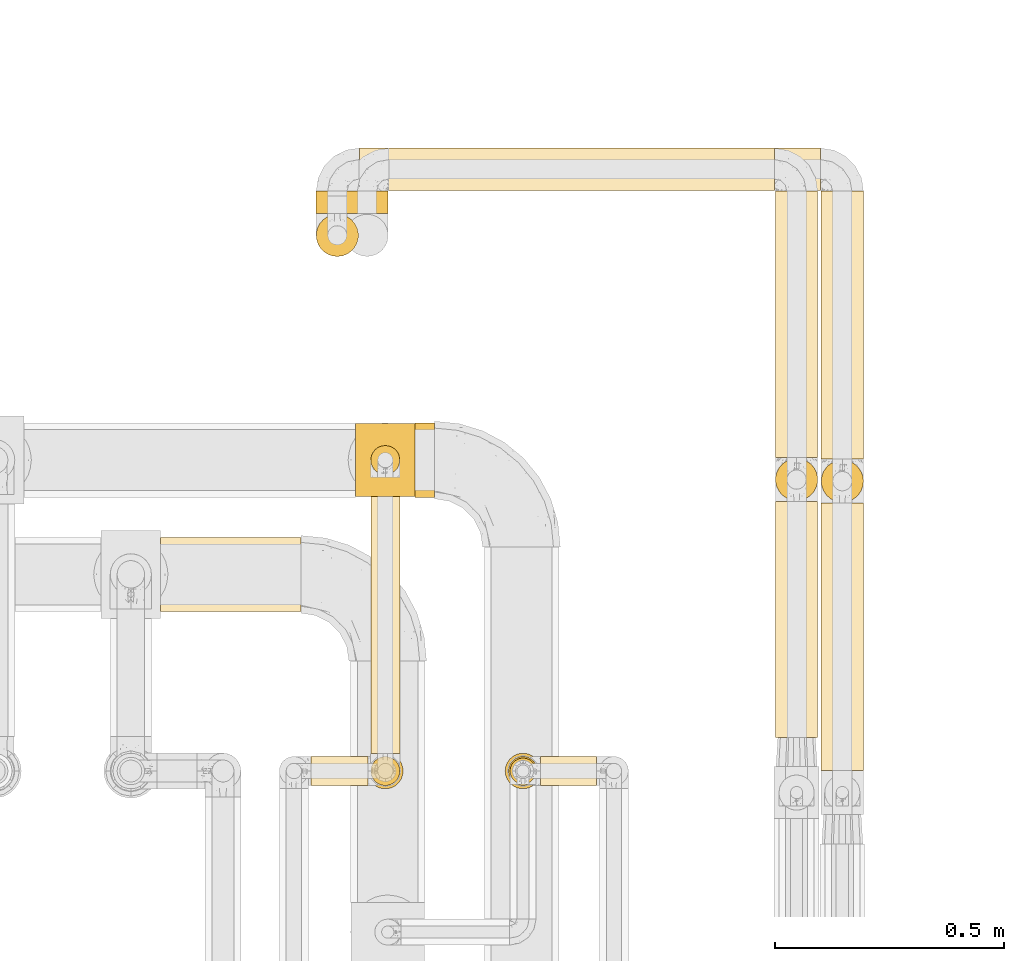
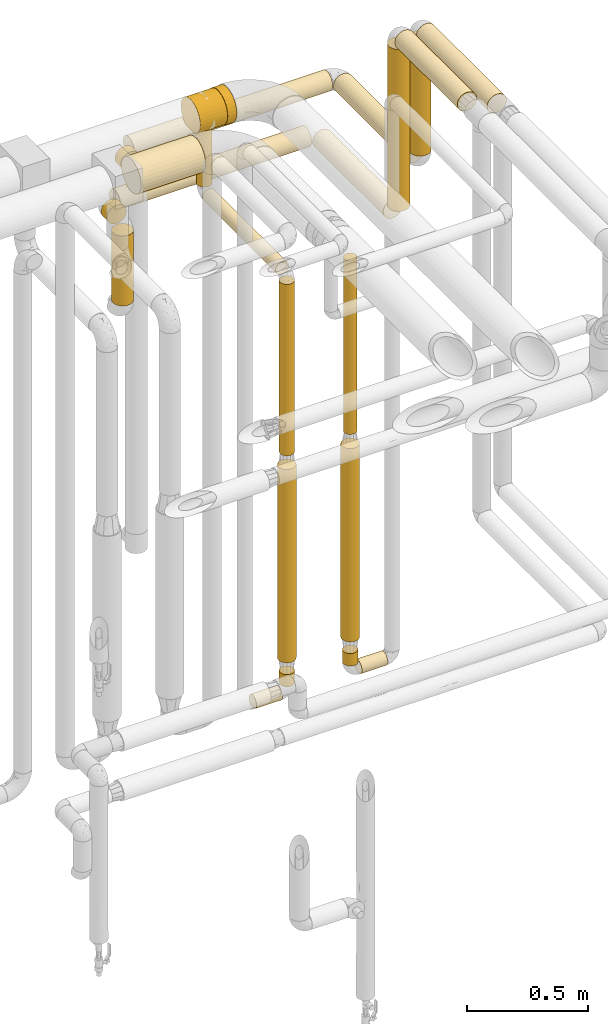
# One storey, part 19 of 827: 24 coverings.
"""IFC2X3 building model written with IfcOpenShell, lengths in millimetres."""

from ifc_helpers import new_model, entity, si_unit, converted_unit, derived_unit, direction, frame, frame_2d, origin, origin_2d_with_axis, place, context, subcontext, project, spatial, polyline, circle_curve, parameter, trimmed, segment, composite_curve, circle, outline, extrude, element, save


model = new_model("IFC2X3")

# Units and contexts
model_context = context("Model", 3, precision=0.01, world=origin(), true_north=direction((6.12303176911189e-17, 1.0)))
body_context = subcontext(model_context, "Body", "Model", "MODEL_VIEW")
ifc_project = project(units=[si_unit("LENGTHUNIT", "METRE", prefix="MILLI"), si_unit("AREAUNIT", "SQUARE_METRE"), si_unit("VOLUMEUNIT", "CUBIC_METRE"), converted_unit("PLANEANGLEUNIT", "DEGREE", entity("IfcRatioMeasure", 0.0174532925199433), si_unit("PLANEANGLEUNIT", "RADIAN"), dimensions=[0, 0, 0, 0, 0, 0, 0]), si_unit("MASSUNIT", "GRAM", prefix="KILO"), derived_unit("MASSDENSITYUNIT", [(si_unit("MASSUNIT", "GRAM", prefix="KILO"), 1), (si_unit("LENGTHUNIT", "METRE"), -3)]), derived_unit("MOMENTOFINERTIAUNIT", [(si_unit("LENGTHUNIT", "METRE"), 4)]), si_unit("TIMEUNIT", "SECOND"), si_unit("FREQUENCYUNIT", "HERTZ"), si_unit("THERMODYNAMICTEMPERATUREUNIT", "DEGREE_CELSIUS"), derived_unit("THERMALTRANSMITTANCEUNIT", [(si_unit("MASSUNIT", "GRAM", prefix="KILO"), 1), (si_unit("THERMODYNAMICTEMPERATUREUNIT", "KELVIN"), -1), (si_unit("TIMEUNIT", "SECOND"), -3)]), derived_unit("VOLUMETRICFLOWRATEUNIT", [(si_unit("LENGTHUNIT", "METRE"), 3), (si_unit("TIMEUNIT", "SECOND"), -1)]), derived_unit("MASSFLOWRATEUNIT", [(si_unit("MASSUNIT", "GRAM", prefix="KILO"), 1), (si_unit("TIMEUNIT", "SECOND"), -1)]), derived_unit("ROTATIONALFREQUENCYUNIT", [(si_unit("TIMEUNIT", "SECOND"), -1)]), si_unit("ELECTRICCURRENTUNIT", "AMPERE"), si_unit("ELECTRICVOLTAGEUNIT", "VOLT"), si_unit("POWERUNIT", "WATT"), si_unit("FORCEUNIT", "NEWTON", prefix="KILO"), si_unit("ILLUMINANCEUNIT", "LUX"), si_unit("LUMINOUSFLUXUNIT", "LUMEN"), si_unit("LUMINOUSINTENSITYUNIT", "CANDELA"), derived_unit("USERDEFINED", [(si_unit("MASSUNIT", "GRAM", prefix="KILO"), -1), (si_unit("LENGTHUNIT", "METRE"), -2), (si_unit("TIMEUNIT", "SECOND"), 3), (si_unit("LUMINOUSFLUXUNIT", "LUMEN"), 1)]), derived_unit("LINEARVELOCITYUNIT", [(si_unit("LENGTHUNIT", "METRE"), 1), (si_unit("TIMEUNIT", "SECOND"), -1)]), si_unit("PRESSUREUNIT", "PASCAL"), derived_unit("USERDEFINED", [(si_unit("LENGTHUNIT", "METRE"), -2), (si_unit("MASSUNIT", "GRAM", prefix="KILO"), 1), (si_unit("TIMEUNIT", "SECOND"), -2)]), derived_unit("LINEARFORCEUNIT", [(si_unit("MASSUNIT", "GRAM", prefix="KILO"), 1), (si_unit("LENGTHUNIT", "METRE"), 1), (si_unit("TIMEUNIT", "SECOND"), -2), (si_unit("LENGTHUNIT", "METRE"), -1)]), derived_unit("PLANARFORCEUNIT", [(si_unit("MASSUNIT", "GRAM", prefix="KILO"), 1), (si_unit("LENGTHUNIT", "METRE"), 1), (si_unit("TIMEUNIT", "SECOND"), -2), (si_unit("LENGTHUNIT", "METRE"), -2)])], contexts=[model_context])

# Site, building, storey
site_placement = place(None, origin())
site = spatial("IfcSite", under=ifc_project, at=site_placement, CompositionType="ELEMENT")
building_placement = place(site_placement, origin())
building = spatial("IfcBuilding", under=site, at=building_placement, CompositionType="ELEMENT")
storey_placement = place(building_placement, frame((0.0, 0.0, 28200.0)))
storey = spatial("IfcBuildingStorey", under=building, at=storey_placement, Name="08", CompositionType="ELEMENT", Elevation=28200.0)

# Coverings
covering_1_placement = place(storey_placement, frame((60424.39, 17470.0, 1600.0)))
element("IfcCovering", 1, at=covering_1_placement, inside=storey, Name=":ADSK_", ObjectType=":ADSK_", PredefinedType="INSULATION", context=body_context, shape_type="SweptSolid", body=[
    extrude(circle(Radius=28.4, at=origin_2d_with_axis()), frame((30.0, 30.0, 0.0), z_axis=(0.0, 0.0, 1.0), x_axis=(-1.0, 0.0, 0.0)), (0.0, 0.0, 1.0), 872.894988927772),
])
covering_2_placement = place(storey_placement, frame((61004.89, 17573.83, 2952.0)))
element("IfcCovering", 2, at=covering_2_placement, inside=storey, Name=":ADSK_", ObjectType=":ADSK_", PredefinedType="INSULATION", context=body_context, shape_type="SweptSolid", body=[
    extrude(circle(Radius=46.15, at=origin_2d_with_axis()), frame((47.75, 0.0, 47.75), z_axis=(0.0, 1.0, 0.0), x_axis=(-1.0, 0.0, 0.0)), (0.0, 0.0, 1.0), 515.500000000028),
])
covering_3_placement = place(storey_placement, frame((61004.89, 18089.59, 2137.37)))
element("IfcCovering", 3, at=covering_3_placement, inside=storey, Name=":ADSK_", ObjectType=":ADSK_", PredefinedType="INSULATION", context=body_context, shape_type="SweptSolid", body=[
    extrude(circle(Radius=46.15, at=origin_2d_with_axis()), frame((47.75, 47.75, 0.0), z_axis=(0.0, 0.0, 1.0), x_axis=(0.0, 1.0, 0.0)), (0.0, 0.0, 1.0), 814.370023810611),
])
covering_4_placement = place(storey_placement, frame((61004.89, 18185.33, 2041.63)))
element("IfcCovering", 4, at=covering_4_placement, inside=storey, Name=":ADSK_", ObjectType=":ADSK_", PredefinedType="INSULATION", context=body_context, shape_type="SweptSolid", body=[
    extrude(circle(Radius=46.15, at=origin_2d_with_axis()), frame((47.75, 0.0, 47.75), z_axis=(0.0, 1.0, 0.0), x_axis=(-1.0, 0.0, 0.0)), (0.0, 0.0, 1.0), 582.616004091368),
])
covering_5_placement = place(storey_placement, frame((61104.89, 17500.83, 2952.0)))
element("IfcCovering", 5, at=covering_5_placement, inside=storey, Name=":ADSK_", ObjectType=":ADSK_", PredefinedType="INSULATION", context=body_context, shape_type="SweptSolid", body=[
    extrude(circle(Radius=46.15, at=origin_2d_with_axis()), frame((47.75, 0.0, 47.75), z_axis=(0.0, 1.0, 0.0), x_axis=(-1.0, 0.0, 0.0)), (0.0, 0.0, 1.0), 585.000000000008),
])
covering_6_placement = place(storey_placement, frame((59661.67, 17847.0, 2816.87)))
element("IfcCovering", 6, at=covering_6_placement, inside=storey, Name=":ADSK_", ObjectType=":ADSK_", PredefinedType="INSULATION", context=body_context, shape_type="SweptSolid", body=[
    extrude(circle(Radius=81.5, at=origin_2d_with_axis()), frame((0.0, 83.1, 83.1), z_axis=(1.0, 0.0, 0.0), x_axis=(0.0, -1.0, 0.0)), (0.0, 0.0, 1.0), 306.875508273996),
])
covering_7_placement = place(storey_placement, frame((60161.17, 18768.35, 2287.0)))
element("IfcCovering", 7, at=covering_7_placement, inside=storey, Name=":ADSK_", ObjectType=":ADSK_", PredefinedType="INSULATION", context=body_context, shape_type="SweptSolid", body=[
    extrude(circle(Radius=46.15, at=origin_2d_with_axis()), frame((0.0, 47.75, 47.75), z_axis=(1.0, 0.0, 0.0), x_axis=(0.0, -1.0, 0.0)), (0.0, 0.0, 1.0), 943.465172144308),
])
covering_8_placement = place(storey_placement, frame((60096.17, 18768.2, 2041.63)))
element("IfcCovering", 8, at=covering_8_placement, inside=storey, Name=":ADSK_", ObjectType=":ADSK_", PredefinedType="INSULATION", context=body_context, shape_type="SweptSolid", body=[
    extrude(circle(Radius=46.15, at=origin_2d_with_axis()), frame((0.01, 47.89, 47.75), z_axis=(0.999999986826571, -0.000162317151743365, 0.0), x_axis=(-0.000162317151743365, -0.999999986826571, 0.0)), (0.0, 0.0, 1.0), 908.465194111927),
])
covering_9_placement = place(storey_placement, frame((60065.43, 18719.47, 2287.0)))
element("IfcCovering", 9, at=covering_9_placement, inside=storey, Name=":ADSK_", ObjectType=":ADSK_", PredefinedType="INSULATION", context=body_context, shape_type="SweptSolid", body=[
    extrude(circle(Radius=46.15, at=origin_2d_with_axis()), frame((47.75, 0.0, 47.75), z_axis=(0.0, 1.0, 0.0), x_axis=(-1.0, 0.0, 0.0)), (0.0, 0.0, 1.0), 48.6274645694443),
])
covering_10_placement = place(storey_placement, frame((60000.43, 18623.72, 1689.87)))
element("IfcCovering", 10, at=covering_10_placement, inside=storey, Name=":ADSK_", ObjectType=":ADSK_", PredefinedType="INSULATION", context=body_context, shape_type="SweptSolid", body=[
    extrude(circle(Radius=46.15, at=origin_2d_with_axis()), frame((47.75, 47.75, 0.0), z_axis=(0.0, 0.0, 1.0), x_axis=(0.0, -1.0, 0.0)), (0.0, 0.0, 1.0), 351.500000000011),
])
covering_11_placement = place(storey_placement, frame((60000.43, 18719.47, 2041.63)))
element("IfcCovering", 11, at=covering_11_placement, inside=storey, Name=":ADSK_", ObjectType=":ADSK_", PredefinedType="INSULATION", context=body_context, shape_type="SweptSolid", body=[
    extrude(circle(Radius=46.15, at=origin_2d_with_axis()), frame((47.75, 0.0, 47.75), z_axis=(0.0, 1.0, 0.0), x_axis=(-1.0, 0.0, 0.0)), (0.0, 0.0, 1.0), 48.6274645694486),
])
covering_12_placement = place(storey_placement, frame((60492.38, 17466.65, 366.65)))
element("IfcCovering", 12, at=covering_12_placement, inside=storey, Name=":ADSK_", ObjectType=":ADSK_", PredefinedType="INSULATION", context=body_context, shape_type="SweptSolid", body=[
    extrude(circle(Radius=31.75, at=origin_2d_with_axis()), frame((0.0, 33.35, 33.35), z_axis=(1.0, 0.0, 0.0), x_axis=(0.0, -1.0, 0.0)), (0.0, 0.0, 1.0), 122.750000000028),
])
covering_13_placement = place(storey_placement, frame((60421.04, 17466.65, 438.0)))
element("IfcCovering", 13, at=covering_13_placement, inside=storey, Name=":ADSK_", ObjectType=":ADSK_", PredefinedType="INSULATION", context=body_context, shape_type="SweptSolid", body=[
    extrude(circle(Radius=31.75, at=origin_2d_with_axis()), frame((33.35, 33.35, 0.0)), (0.0, 0.0, 1.0), 62.0000000000162),
])
covering_14_placement = place(storey_placement, frame((60413.79, 17459.4, 564.0)))
element("IfcCovering", 14, at=covering_14_placement, inside=storey, Name=":ADSK_", ObjectType=":ADSK_", PredefinedType="INSULATION", context=body_context, shape_type="SweptSolid", body=[
    extrude(circle(Radius=39.0, at=origin_2d_with_axis()), frame((40.6, 40.6, 0.0)), (0.0, 0.0, 1.0), 971.999999999987),
])
covering_15_placement = place(storey_placement, frame((60119.79, 17538.0, 2466.65)))
element("IfcCovering", 15, at=covering_15_placement, inside=storey, Name=":ADSK_", ObjectType=":ADSK_", PredefinedType="INSULATION", context=body_context, shape_type="SweptSolid", body=[
    extrude(circle(Radius=31.75, at=origin_2d_with_axis()), frame((33.35, 0.0, 33.35), z_axis=(0.0, 1.0, 0.0), x_axis=(1.0, 0.0, 0.0)), (0.0, 0.0, 1.0), 604.096114108988),
])
covering_16_placement = place(storey_placement, frame((60119.79, 18146.75, 2538.0)))
element("IfcCovering", 16, at=covering_16_placement, inside=storey, Name=":ADSK_", ObjectType=":ADSK_", PredefinedType="INSULATION", context=body_context, shape_type="SweptSolid", body=[
    extrude(circle(Radius=31.75, at=origin_2d_with_axis()), frame((33.35, 33.35, 0.0), z_axis=(0.0, 0.0, 1.0), x_axis=(0.0, -1.0, 0.0)), (0.0, 0.0, 1.0), 291.999999999986),
])
covering_17_placement = place(storey_placement, frame((60218.13, 18097.0, 2816.9)))
element("IfcCovering", 17, at=covering_17_placement, inside=storey, Name=":ADSK_", ObjectType=":ADSK_", PredefinedType="INSULATION", context=body_context, shape_type="SweptSolid", body=[
    extrude(circle(Radius=81.5, at=origin_2d_with_axis()), frame((0.0, 83.1, 83.1), z_axis=(1.0, 0.0, 0.0), x_axis=(0.0, -1.0, 0.0)), (0.0, 0.0, 1.0), 42.9168860607221),
])
covering_18_placement = place(storey_placement, frame((60119.79, 17466.65, 1600.0)))
element("IfcCovering", 18, at=covering_18_placement, inside=storey, Name=":ADSK_", ObjectType=":ADSK_", PredefinedType="INSULATION", context=body_context, shape_type="SweptSolid", body=[
    extrude(circle(Radius=31.75, at=origin_2d_with_axis()), frame((33.35, 33.35, 0.0), z_axis=(0.0, 0.0, 1.0), x_axis=(0.0, -1.0, 0.0)), (0.0, 0.0, 1.0), 862.000000000012),
])
covering_19_placement = place(storey_placement, frame((59991.13, 17466.65, 366.65)))
element("IfcCovering", 19, at=covering_19_placement, inside=storey, Name=":ADSK_", ObjectType=":ADSK_", PredefinedType="INSULATION", context=body_context, shape_type="SweptSolid", body=[
    extrude(circle(Radius=31.75, at=origin_2d_with_axis()), frame((0.0, 33.35, 33.35), z_axis=(1.0, 0.0, 0.0), x_axis=(0.0, 1.0, 0.0)), (0.0, 0.0, 1.0), 124.000000000015),
])
covering_20_placement = place(storey_placement, frame((60119.79, 17466.65, 438.0)))
element("IfcCovering", 20, at=covering_20_placement, inside=storey, Name=":ADSK_", ObjectType=":ADSK_", PredefinedType="INSULATION", context=body_context, shape_type="SweptSolid", body=[
    extrude(circle(Radius=31.75, at=origin_2d_with_axis()), frame((33.35, 33.35, 0.0)), (0.0, 0.0, 1.0), 62.0000000000119),
])
covering_21_placement = place(storey_placement, frame((60112.54, 17459.4, 564.0)))
element("IfcCovering", 21, at=covering_21_placement, inside=storey, Name=":ADSK_", ObjectType=":ADSK_", PredefinedType="INSULATION", context=body_context, shape_type="SweptSolid", body=[
    extrude(circle(Radius=39.0, at=origin_2d_with_axis()), frame((40.6, 40.6, 0.0), z_axis=(0.0, 0.0, 1.0), x_axis=(-1.0, 0.0, 0.0)), (0.0, 0.0, 1.0), 971.999999999991),
])
covering_22_placement = place(storey_placement, frame((61104.89, 18086.09, 2382.74)))
element("IfcCovering", 22, at=covering_22_placement, inside=storey, Name=":ADSK_", ObjectType=":ADSK_", PredefinedType="INSULATION", context=body_context, shape_type="SweptSolid", body=[
    extrude(circle(Radius=46.15, at=origin_2d_with_axis()), frame((47.75, 47.75, 0.0), z_axis=(0.0, 0.0, 1.0), x_axis=(-1.0, 0.0, 0.0)), (0.0, 0.0, 1.0), 569.000000000035),
])
covering_23_placement = place(storey_placement, frame((61104.89, 18181.83, 2287.0)))
element("IfcCovering", 23, at=covering_23_placement, inside=storey, Name=":ADSK_", ObjectType=":ADSK_", PredefinedType="INSULATION", context=body_context, shape_type="SweptSolid", body=[
    extrude(circle(Radius=46.15, at=origin_2d_with_axis()), frame((47.75, 0.0, 47.75), z_axis=(0.0, 1.0, 0.0), x_axis=(-1.0, 0.0, 0.0)), (0.0, 0.0, 1.0), 586.263463574079),
])
covering_24_placement = place(storey_placement, frame((60088.13, 18098.5, 2828.4)))
element("IfcCovering", 24, at=covering_24_placement, inside=storey, Name=":ADSK_", ObjectType=":ADSK_", PredefinedType="INSULATION", context=body_context, shape_type="SweptSolid", body=[
    extrude(outline(composite_curve([segment(trimmed(circle_curve(frame_2d((12.0, 0.0), x_axis=(1.0, 0.0)), 80.0), [parameter(0.0)], [parameter(90.0)], True, "PARAMETER"), True, "CONTINUOUS"), segment(trimmed(circle_curve(frame_2d((12.0, 0.0), x_axis=(1.0, 0.0)), 80.0), [parameter(90.0)], [parameter(151.044975628142)], True, "PARAMETER"), True, "CONTINUOUS"), segment(polyline([(-58.0, 38.73), (-58.0, -38.73)]), True, "CONTINUOUS"), segment(trimmed(circle_curve(frame_2d((12.0, 0.0), x_axis=(1.0, 0.0)), 80.0), [parameter(208.955024371858)], [parameter(270.0)], True, "PARAMETER"), True, "CONTINUOUS"), segment(trimmed(circle_curve(frame_2d((12.0, 0.0), x_axis=(1.0, 0.0)), 80.0), [parameter(270.0)], [parameter(0.0)], True, "PARAMETER"), True, "CONTINUOUS")], self_intersect=False)), frame((0.0, 81.6, 59.6), z_axis=(1.0, 0.0, 0.0), x_axis=(0.0, 0.0, 1.0)), (0.0, 0.0, 1.0), 129.999999999996),
])

save(model, "model.ifc")
